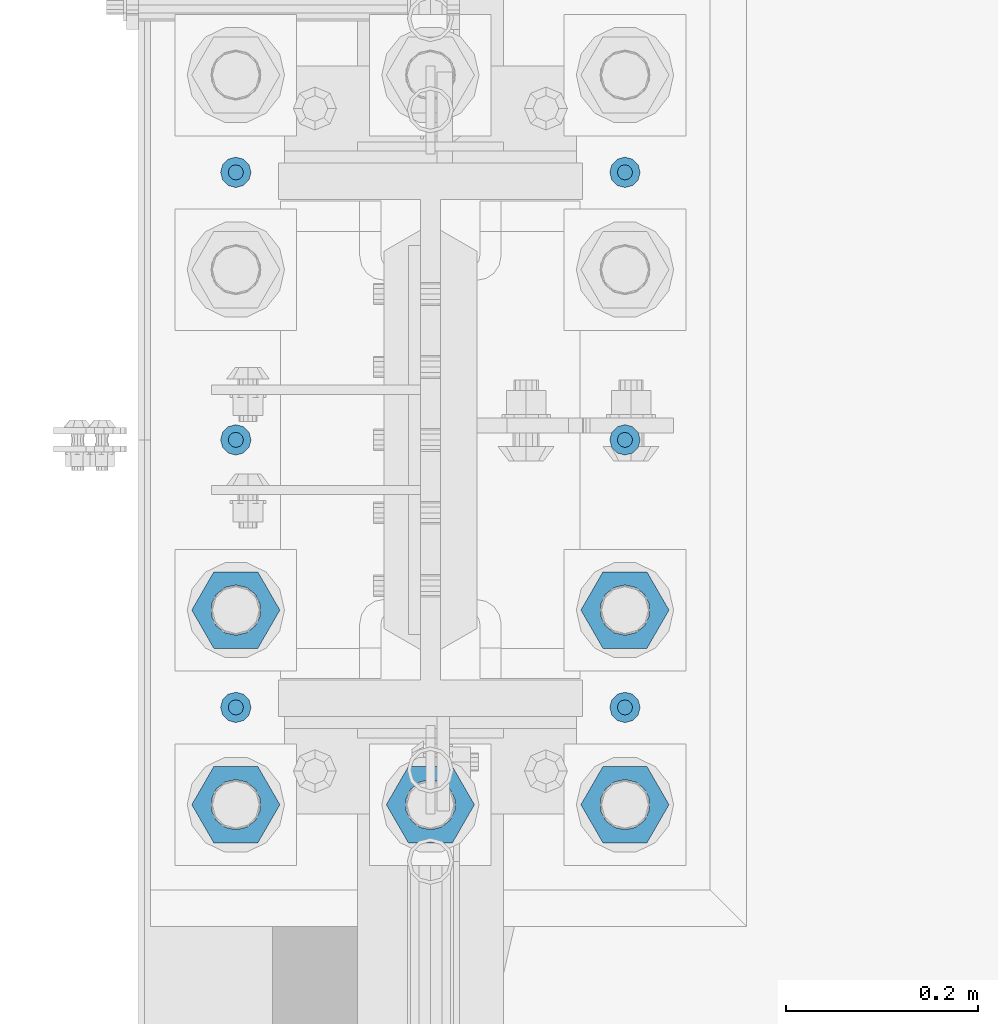
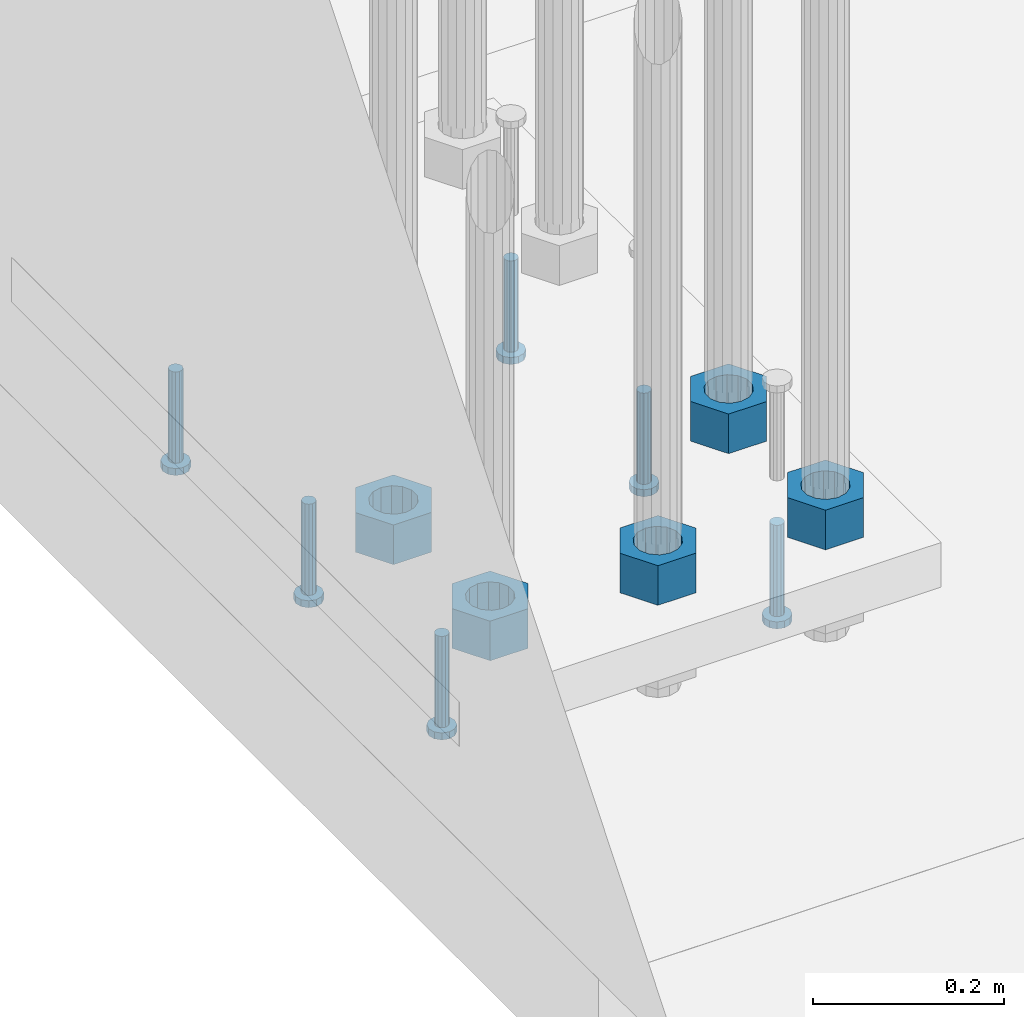
# One storey, part 1290 of 1876: 11 beams, 1 element without a shape of its own.
"""IFC2X3 building model written with IfcOpenShell, lengths in millimetres."""

from ifc_helpers import new_model, si_unit, frame, origin_with_axes, place, context, subcontext, project, spatial, faceted_brep, material, type_object, element, aggregate, save


model = new_model("IFC2X3")

# Units and contexts
model_context = context("Model", 3, precision=1e-05, world=origin_with_axes())
body_context = subcontext(model_context, "Body", "Model", "MODEL_VIEW")
ifc_project = project(units=[si_unit("LENGTHUNIT", "METRE", prefix="MILLI"), si_unit("AREAUNIT", "SQUARE_METRE"), si_unit("VOLUMEUNIT", "CUBIC_METRE"), si_unit("MASSUNIT", "GRAM", prefix="KILO"), si_unit("TIMEUNIT", "SECOND"), si_unit("PLANEANGLEUNIT", "RADIAN"), si_unit("SOLIDANGLEUNIT", "STERADIAN"), si_unit("THERMODYNAMICTEMPERATUREUNIT", "DEGREE_CELSIUS"), si_unit("LUMINOUSINTENSITYUNIT", "LUMEN")], contexts=[model_context])

# Site, building, storey
site_placement = place(None, origin_with_axes())
site = spatial("IfcSite", under=ifc_project, at=site_placement, CompositionType="ELEMENT")
building_placement = place(site_placement, origin_with_axes())
building = spatial("IfcBuilding", under=site, at=building_placement, Name="Undefined", CompositionType="ELEMENT")
storey_placement = place(building_placement, origin_with_axes())
storey = spatial("IfcBuildingStorey", under=building, at=storey_placement, Name="Undefined", CompositionType="ELEMENT", Elevation=0.0)

# Assembly, beams
assembly_placement = place(storey_placement, origin_with_axes())
assembly = element("IfcElementAssembly", 1, at=assembly_placement, inside=storey, Name="TEMPLATE", AssemblyPlace="NOTDEFINED", PredefinedType="RIGID_FRAME")
ifc_material_1 = material(Name="STEEL/A563")
beam_type_1 = type_object("IfcBeamType", Name="2_HEAVY_HEX_NUT", PredefinedType="NOTDEFINED")
beam_1_placement = place(assembly_placement, frame((-203.2, 7238.99999847412, -685.799998474121), z_axis=(0.0, -1.0, 0.0), x_axis=(0.0, 0.0, -1.0)))
beam_1 = element("IfcBeam", 2, at=beam_1_placement, type_object=beam_type_1, material=ifc_material_1, Name="NUT", ObjectType="2_HEAVY_HEX_NUT", context=body_context, shape_type="Brep", body=[
    faceted_brep([(0.0, -46.0369987487793, 9.09494701772928e-13), (0.0, -23.0184993743896, -39.869213104248), (50.8, -23.0184993743896, -39.869213104248), (50.8, -46.0369987487793, 9.09494701772928e-13), (0.0, 23.0184993743896, -39.869213104248), (50.8, 23.0184993743896, -39.869213104248), (0.0, 46.0369987487793, -9.09494701772928e-13), (50.8, 46.0369987487793, -9.09494701772928e-13), (0.0, 23.0184993743896, 39.869213104248), (50.8, 23.0184993743896, 39.869213104248), (0.0, -23.0184993743896, 39.869213104248), (50.8, -23.0184993743896, 39.869213104248), (0.0, 0.0, 26.1940002441406), (0.0, 11.3650617044514, 23.5999013092769), (50.8, 11.3650617044513, 23.5999013092771), (50.8, 0.0, 26.1940002441406), (0.0, 20.4791109456437, 16.3316083006703), (50.8, 20.4791109456439, 16.3316083006703), (0.0, 25.5370200498346, 5.82867859874477), (50.8, 25.5370200498343, 5.82867859874455), (0.0, 25.5370200498346, -5.82867859874477), (50.8, 25.5370200498343, -5.82867859874455), (0.0, 20.4791109456437, -16.3316083006703), (50.8, 20.4791109456439, -16.3316083006703), (0.0, 11.3650617044514, -23.5999013092769), (50.8, 11.3650617044514, -23.5999013092771), (0.0, 0.0, -26.1940002441406), (50.8, 0.0, -26.1940002441406), (0.0, -11.3650617044514, -23.5999013092769), (50.8, -11.3650617044513, -23.5999013092771), (0.0, -20.4791109456437, -16.3316083006703), (50.8, -20.4791109456439, -16.3316083006703), (0.0, -25.5370200498346, -5.82867859874477), (50.8, -25.5370200498343, -5.82867859874455), (0.0, -25.5370200498346, 5.82867859874477), (50.8, -25.5370200498343, 5.82867859874455), (0.0, -20.4791109456437, 16.3316083006703), (50.8, -20.4791109456439, 16.3316083006703), (0.0, -11.3650617044514, 23.5999013092769), (50.8, -11.3650617044514, 23.5999013092771)], [[[0, 1, 2, 3]], [[1, 4, 5, 2]], [[4, 6, 7, 5]], [[6, 8, 9, 7]], [[8, 10, 11, 9]], [[10, 0, 3, 11]], [[12, 13, 14, 15]], [[13, 16, 17, 14]], [[16, 18, 19, 17]], [[18, 20, 21, 19]], [[20, 22, 23, 21]], [[22, 24, 25, 23]], [[24, 26, 27, 25]], [[26, 28, 29, 27]], [[28, 30, 31, 29]], [[30, 32, 33, 31]], [[32, 34, 35, 33]], [[34, 36, 37, 35]], [[36, 38, 39, 37]], [[38, 12, 15, 39]], [[5, 7, 9, 11, 3, 2], [17, 19, 21, 23, 25, 27, 29, 31, 33, 35, 37, 39, 15, 14]], [[10, 8, 6, 4, 1, 0], [38, 36, 34, 32, 30, 28, 26, 24, 22, 20, 18, 16, 13, 12]]]),
])
beam_2_placement = place(assembly_placement, frame((0.0, 7238.99999847412, -685.799998474121), z_axis=(0.0, -1.0, 0.0), x_axis=(0.0, 0.0, -1.0)))
beam_2 = element("IfcBeam", 3, at=beam_2_placement, type_object=beam_type_1, material=ifc_material_1, Name="NUT", ObjectType="2_HEAVY_HEX_NUT", context=body_context, shape_type="Brep", body=[
    faceted_brep([(0.0, -46.0369987487793, 9.09494701772928e-13), (0.0, -23.0184993743896, -39.869213104248), (50.8, -23.0184993743896, -39.869213104248), (50.8, -46.0369987487793, 9.09494701772928e-13), (0.0, 23.0184993743896, -39.869213104248), (50.8, 23.0184993743896, -39.869213104248), (0.0, 46.0369987487793, -9.09494701772928e-13), (50.8, 46.0369987487793, -9.09494701772928e-13), (0.0, 23.0184993743896, 39.869213104248), (50.8, 23.0184993743896, 39.869213104248), (0.0, -23.0184993743896, 39.869213104248), (50.8, -23.0184993743896, 39.869213104248), (0.0, 0.0, 26.1940002441406), (0.0, 11.3650617044514, 23.5999013092769), (50.8, 11.3650617044513, 23.5999013092771), (50.8, 0.0, 26.1940002441406), (0.0, 20.4791109456437, 16.3316083006703), (50.8, 20.4791109456439, 16.3316083006703), (0.0, 25.5370200498346, 5.82867859874477), (50.8, 25.5370200498343, 5.82867859874455), (0.0, 25.5370200498346, -5.82867859874477), (50.8, 25.5370200498343, -5.82867859874455), (0.0, 20.4791109456437, -16.3316083006703), (50.8, 20.4791109456439, -16.3316083006703), (0.0, 11.3650617044514, -23.5999013092769), (50.8, 11.3650617044514, -23.5999013092771), (0.0, 0.0, -26.1940002441406), (50.8, 0.0, -26.1940002441406), (0.0, -11.3650617044514, -23.5999013092769), (50.8, -11.3650617044513, -23.5999013092771), (0.0, -20.4791109456437, -16.3316083006703), (50.8, -20.4791109456439, -16.3316083006703), (0.0, -25.5370200498346, -5.82867859874477), (50.8, -25.5370200498343, -5.82867859874455), (0.0, -25.5370200498346, 5.82867859874477), (50.8, -25.5370200498343, 5.82867859874455), (0.0, -20.4791109456437, 16.3316083006703), (50.8, -20.4791109456439, 16.3316083006703), (0.0, -11.3650617044514, 23.5999013092769), (50.8, -11.3650617044514, 23.5999013092771)], [[[0, 1, 2, 3]], [[1, 4, 5, 2]], [[4, 6, 7, 5]], [[6, 8, 9, 7]], [[8, 10, 11, 9]], [[10, 0, 3, 11]], [[12, 13, 14, 15]], [[13, 16, 17, 14]], [[16, 18, 19, 17]], [[18, 20, 21, 19]], [[20, 22, 23, 21]], [[22, 24, 25, 23]], [[24, 26, 27, 25]], [[26, 28, 29, 27]], [[28, 30, 31, 29]], [[30, 32, 33, 31]], [[32, 34, 35, 33]], [[34, 36, 37, 35]], [[36, 38, 39, 37]], [[38, 12, 15, 39]], [[5, 7, 9, 11, 3, 2], [17, 19, 21, 23, 25, 27, 29, 31, 33, 35, 37, 39, 15, 14]], [[10, 8, 6, 4, 1, 0], [38, 36, 34, 32, 30, 28, 26, 24, 22, 20, 18, 16, 13, 12]]]),
])
beam_3_placement = place(assembly_placement, frame((203.2, 7238.99999847412, -685.799998474121), z_axis=(0.0, 1.0, 0.0), x_axis=(0.0, 0.0, -1.0)))
beam_3 = element("IfcBeam", 4, at=beam_3_placement, type_object=beam_type_1, material=ifc_material_1, Name="NUT", ObjectType="2_HEAVY_HEX_NUT", context=body_context, shape_type="Brep", body=[
    faceted_brep([(0.0, -46.0369987487793, 9.09494701772928e-13), (0.0, -23.0184993743896, -39.869213104248), (50.8, -23.0184993743896, -39.869213104248), (50.8, -46.0369987487793, 9.09494701772928e-13), (0.0, 23.0184993743896, -39.869213104248), (50.8, 23.0184993743896, -39.869213104248), (0.0, 46.0369987487793, -9.09494701772928e-13), (50.8, 46.0369987487793, -9.09494701772928e-13), (0.0, 23.0184993743896, 39.869213104248), (50.8, 23.0184993743896, 39.869213104248), (0.0, -23.0184993743896, 39.869213104248), (50.8, -23.0184993743896, 39.869213104248), (0.0, 0.0, 26.1940002441406), (0.0, 11.3650617044514, 23.5999013092769), (50.8, 11.3650617044513, 23.5999013092771), (50.8, 0.0, 26.1940002441406), (0.0, 20.4791109456437, 16.3316083006703), (50.8, 20.4791109456439, 16.3316083006703), (0.0, 25.5370200498346, 5.82867859874477), (50.8, 25.5370200498343, 5.82867859874455), (0.0, 25.5370200498346, -5.82867859874477), (50.8, 25.5370200498343, -5.82867859874455), (0.0, 20.4791109456437, -16.3316083006703), (50.8, 20.4791109456439, -16.3316083006703), (0.0, 11.3650617044514, -23.5999013092769), (50.8, 11.3650617044514, -23.5999013092771), (0.0, 0.0, -26.1940002441406), (50.8, 0.0, -26.1940002441406), (0.0, -11.3650617044514, -23.5999013092769), (50.8, -11.3650617044513, -23.5999013092771), (0.0, -20.4791109456437, -16.3316083006703), (50.8, -20.4791109456439, -16.3316083006703), (0.0, -25.5370200498346, -5.82867859874477), (50.8, -25.5370200498343, -5.82867859874455), (0.0, -25.5370200498346, 5.82867859874477), (50.8, -25.5370200498343, 5.82867859874455), (0.0, -20.4791109456437, 16.3316083006703), (50.8, -20.4791109456439, 16.3316083006703), (0.0, -11.3650617044514, 23.5999013092769), (50.8, -11.3650617044514, 23.5999013092771)], [[[0, 1, 2, 3]], [[1, 4, 5, 2]], [[4, 6, 7, 5]], [[6, 8, 9, 7]], [[8, 10, 11, 9]], [[10, 0, 3, 11]], [[12, 13, 14, 15]], [[13, 16, 17, 14]], [[16, 18, 19, 17]], [[18, 20, 21, 19]], [[20, 22, 23, 21]], [[22, 24, 25, 23]], [[24, 26, 27, 25]], [[26, 28, 29, 27]], [[28, 30, 31, 29]], [[30, 32, 33, 31]], [[32, 34, 35, 33]], [[34, 36, 37, 35]], [[36, 38, 39, 37]], [[38, 12, 15, 39]], [[5, 7, 9, 11, 3, 2], [17, 19, 21, 23, 25, 27, 29, 31, 33, 35, 37, 39, 15, 14]], [[10, 8, 6, 4, 1, 0], [38, 36, 34, 32, 30, 28, 26, 24, 22, 20, 18, 16, 13, 12]]]),
])
beam_4_placement = place(assembly_placement, frame((-203.2, 7442.19999847412, -685.799998474121), z_axis=(0.0, -1.0, 0.0), x_axis=(0.0, 0.0, -1.0)))
beam_4 = element("IfcBeam", 5, at=beam_4_placement, type_object=beam_type_1, material=ifc_material_1, Name="NUT", ObjectType="2_HEAVY_HEX_NUT", context=body_context, shape_type="Brep", body=[
    faceted_brep([(0.0, -46.0369987487793, 9.09494701772928e-13), (0.0, -23.0184993743896, -39.869213104248), (50.8, -23.0184993743896, -39.869213104248), (50.8, -46.0369987487793, 9.09494701772928e-13), (0.0, 23.0184993743896, -39.869213104248), (50.8, 23.0184993743896, -39.869213104248), (0.0, 46.0369987487793, -9.09494701772928e-13), (50.8, 46.0369987487793, -9.09494701772928e-13), (0.0, 23.0184993743896, 39.869213104248), (50.8, 23.0184993743896, 39.869213104248), (0.0, -23.0184993743896, 39.869213104248), (50.8, -23.0184993743896, 39.869213104248), (0.0, 0.0, 26.1940002441406), (0.0, 11.3650617044514, 23.5999013092769), (50.8, 11.3650617044513, 23.5999013092771), (50.8, 0.0, 26.1940002441406), (0.0, 20.4791109456437, 16.3316083006703), (50.8, 20.4791109456439, 16.3316083006703), (0.0, 25.5370200498346, 5.82867859874477), (50.8, 25.5370200498343, 5.82867859874455), (0.0, 25.5370200498346, -5.82867859874477), (50.8, 25.5370200498343, -5.82867859874455), (0.0, 20.4791109456437, -16.3316083006703), (50.8, 20.4791109456439, -16.3316083006703), (0.0, 11.3650617044514, -23.5999013092769), (50.8, 11.3650617044514, -23.5999013092771), (0.0, 0.0, -26.1940002441406), (50.8, 0.0, -26.1940002441406), (0.0, -11.3650617044514, -23.5999013092769), (50.8, -11.3650617044513, -23.5999013092771), (0.0, -20.4791109456437, -16.3316083006703), (50.8, -20.4791109456439, -16.3316083006703), (0.0, -25.5370200498346, -5.82867859874477), (50.8, -25.5370200498343, -5.82867859874455), (0.0, -25.5370200498346, 5.82867859874477), (50.8, -25.5370200498343, 5.82867859874455), (0.0, -20.4791109456437, 16.3316083006703), (50.8, -20.4791109456439, 16.3316083006703), (0.0, -11.3650617044514, 23.5999013092769), (50.8, -11.3650617044514, 23.5999013092771)], [[[0, 1, 2, 3]], [[1, 4, 5, 2]], [[4, 6, 7, 5]], [[6, 8, 9, 7]], [[8, 10, 11, 9]], [[10, 0, 3, 11]], [[12, 13, 14, 15]], [[13, 16, 17, 14]], [[16, 18, 19, 17]], [[18, 20, 21, 19]], [[20, 22, 23, 21]], [[22, 24, 25, 23]], [[24, 26, 27, 25]], [[26, 28, 29, 27]], [[28, 30, 31, 29]], [[30, 32, 33, 31]], [[32, 34, 35, 33]], [[34, 36, 37, 35]], [[36, 38, 39, 37]], [[38, 12, 15, 39]], [[5, 7, 9, 11, 3, 2], [17, 19, 21, 23, 25, 27, 29, 31, 33, 35, 37, 39, 15, 14]], [[10, 8, 6, 4, 1, 0], [38, 36, 34, 32, 30, 28, 26, 24, 22, 20, 18, 16, 13, 12]]]),
])
beam_5_placement = place(assembly_placement, frame((203.2, 7442.19999847412, -685.799998474121), z_axis=(0.0, 1.0, 0.0), x_axis=(0.0, 0.0, -1.0)))
beam_5 = element("IfcBeam", 6, at=beam_5_placement, type_object=beam_type_1, material=ifc_material_1, Name="NUT", ObjectType="2_HEAVY_HEX_NUT", context=body_context, shape_type="Brep", body=[
    faceted_brep([(0.0, -46.0369987487793, 9.09494701772928e-13), (0.0, -23.0184993743896, -39.869213104248), (50.8, -23.0184993743896, -39.869213104248), (50.8, -46.0369987487793, 9.09494701772928e-13), (0.0, 23.0184993743896, -39.869213104248), (50.8, 23.0184993743896, -39.869213104248), (0.0, 46.0369987487793, -9.09494701772928e-13), (50.8, 46.0369987487793, -9.09494701772928e-13), (0.0, 23.0184993743896, 39.869213104248), (50.8, 23.0184993743896, 39.869213104248), (0.0, -23.0184993743896, 39.869213104248), (50.8, -23.0184993743896, 39.869213104248), (0.0, 0.0, 26.1940002441406), (0.0, 11.3650617044514, 23.5999013092769), (50.8, 11.3650617044513, 23.5999013092771), (50.8, 0.0, 26.1940002441406), (0.0, 20.4791109456437, 16.3316083006703), (50.8, 20.4791109456439, 16.3316083006703), (0.0, 25.5370200498346, 5.82867859874477), (50.8, 25.5370200498343, 5.82867859874455), (0.0, 25.5370200498346, -5.82867859874477), (50.8, 25.5370200498343, -5.82867859874455), (0.0, 20.4791109456437, -16.3316083006703), (50.8, 20.4791109456439, -16.3316083006703), (0.0, 11.3650617044514, -23.5999013092769), (50.8, 11.3650617044514, -23.5999013092771), (0.0, 0.0, -26.1940002441406), (50.8, 0.0, -26.1940002441406), (0.0, -11.3650617044514, -23.5999013092769), (50.8, -11.3650617044513, -23.5999013092771), (0.0, -20.4791109456437, -16.3316083006703), (50.8, -20.4791109456439, -16.3316083006703), (0.0, -25.5370200498346, -5.82867859874477), (50.8, -25.5370200498343, -5.82867859874455), (0.0, -25.5370200498346, 5.82867859874477), (50.8, -25.5370200498343, 5.82867859874455), (0.0, -20.4791109456437, 16.3316083006703), (50.8, -20.4791109456439, 16.3316083006703), (0.0, -11.3650617044514, 23.5999013092769), (50.8, -11.3650617044514, 23.5999013092771)], [[[0, 1, 2, 3]], [[1, 4, 5, 2]], [[4, 6, 7, 5]], [[6, 8, 9, 7]], [[8, 10, 11, 9]], [[10, 0, 3, 11]], [[12, 13, 14, 15]], [[13, 16, 17, 14]], [[16, 18, 19, 17]], [[18, 20, 21, 19]], [[20, 22, 23, 21]], [[22, 24, 25, 23]], [[24, 26, 27, 25]], [[26, 28, 29, 27]], [[28, 30, 31, 29]], [[30, 32, 33, 31]], [[32, 34, 35, 33]], [[34, 36, 37, 35]], [[36, 38, 39, 37]], [[38, 12, 15, 39]], [[5, 7, 9, 11, 3, 2], [17, 19, 21, 23, 25, 27, 29, 31, 33, 35, 37, 39, 15, 14]], [[10, 8, 6, 4, 1, 0], [38, 36, 34, 32, 30, 28, 26, 24, 22, 20, 18, 16, 13, 12]]]),
])
ifc_material_2 = material(Name="STEEL/A108")
beam_type_2 = type_object("IfcBeamType", Name="5/8-DIA_HEADED ANCHOR STUD", PredefinedType="NOTDEFINED")
beam_6_placement = place(assembly_placement, frame((203.2, 7899.4, -793.75), z_axis=(1.0, 0.0, 0.0), x_axis=(0.0, 0.0, -1.0)))
beam_6 = element("IfcBeam", 7, at=beam_6_placement, type_object=beam_type_2, material=ifc_material_2, Name="HEADED ANCHOR STUD", ObjectType="5/8-DIA_HEADED ANCHOR STUD", context=body_context, shape_type="Brep", body=[
    faceted_brep([(0.0, -7.94000005722046, 0.0), (0.0, -6.86999988555908, -3.97000002861023), (116.84, -6.86999988555908, -3.97000002861023), (116.84, -7.94000005722046, 0.0), (0.0, -3.97000002861023, -6.86999988555908), (116.84, -3.97000002861023, -6.86999988555908), (0.0, 0.0, -7.94000005722046), (116.84, 0.0, -7.94000005722046), (0.0, 3.97000002861023, -6.86999988555908), (116.84, 3.97000002861023, -6.86999988555908), (0.0, 6.86999988555908, -3.97000002861023), (116.84, 6.86999988555908, -3.97000002861023), (0.0, 7.94000005722046, 0.0), (116.84, 7.94000005722046, 0.0), (0.0, 6.86999988555908, 3.97000002861023), (116.84, 6.86999988555908, 3.97000002861023), (0.0, 3.97000002861023, 6.86999988555908), (116.84, 3.97000002861023, 6.86999988555908), (0.0, 0.0, 7.94000005722046), (116.84, 0.0, 7.94000005722046), (0.0, -3.97000002861023, 6.86999988555908), (116.84, -3.97000002861023, 6.86999988555908), (0.0, -6.86999988555908, 3.97000002861023), (116.84, -6.86999988555908, 3.97000002861023), (118.11, -13.75, -7.94000005722046), (118.11, -15.8800001144409, 0.0), (118.11, -7.94000005722046, -13.75), (118.11, 0.0, -15.8800001144409), (118.11, 7.94000005722046, -13.75), (118.11, 13.75, -7.94000005722046), (118.11, 15.8800001144409, 0.0), (118.11, 13.75, 7.94000005722046), (118.11, 7.94000005722046, 13.75), (118.11, 0.0, 15.8800001144409), (118.11, -7.94000005722046, 13.75), (118.11, -13.75, 7.94000005722046), (127.0, -13.75, -7.94000005722046), (127.0, -15.8800001144409, 0.0), (127.0, -7.94000005722046, -13.75), (127.0, 0.0, -15.8800001144409), (127.0, 7.94000005722046, -13.75), (127.0, 13.75, -7.94000005722046), (127.0, 15.8800001144409, 0.0), (127.0, 13.75, 7.94000005722046), (127.0, 7.94000005722046, 13.75), (127.0, 0.0, 15.8800001144409), (127.0, -7.94000005722046, 13.75), (127.0, -13.75, 7.94000005722046)], [[[0, 1, 2, 3]], [[1, 4, 5, 2]], [[4, 6, 7, 5]], [[6, 8, 9, 7]], [[8, 10, 11, 9]], [[10, 12, 13, 11]], [[12, 14, 15, 13]], [[14, 16, 17, 15]], [[16, 18, 19, 17]], [[18, 20, 21, 19]], [[20, 22, 23, 21]], [[22, 0, 3, 23]], [[22, 20, 18, 16, 14, 12, 10, 8, 6, 4, 1, 0]], [[3, 2, 24, 25]], [[2, 5, 26, 24]], [[5, 7, 27, 26]], [[7, 9, 28, 27]], [[9, 11, 29, 28]], [[11, 13, 30, 29]], [[13, 15, 31, 30]], [[15, 17, 32, 31]], [[17, 19, 33, 32]], [[19, 21, 34, 33]], [[21, 23, 35, 34]], [[23, 3, 25, 35]], [[25, 24, 36, 37]], [[24, 26, 38, 36]], [[26, 27, 39, 38]], [[27, 28, 40, 39]], [[28, 29, 41, 40]], [[29, 30, 42, 41]], [[30, 31, 43, 42]], [[31, 32, 44, 43]], [[32, 33, 45, 44]], [[33, 34, 46, 45]], [[34, 35, 47, 46]], [[35, 25, 37, 47]], [[38, 39, 40, 41, 42, 43, 44, 45, 46, 47, 37, 36]]]),
])
beam_7_placement = place(assembly_placement, frame((203.2, 7340.6, -793.75), z_axis=(1.0, 0.0, 0.0), x_axis=(0.0, 0.0, -1.0)))
beam_7 = element("IfcBeam", 8, at=beam_7_placement, type_object=beam_type_2, material=ifc_material_2, Name="HEADED ANCHOR STUD", ObjectType="5/8-DIA_HEADED ANCHOR STUD", context=body_context, shape_type="Brep", body=[
    faceted_brep([(0.0, -7.94000005722046, 0.0), (0.0, -6.86999988555908, -3.97000002861023), (116.84, -6.86999988555908, -3.97000002861023), (116.84, -7.94000005722046, 0.0), (0.0, -3.97000002861023, -6.86999988555908), (116.84, -3.97000002861023, -6.86999988555908), (0.0, 0.0, -7.94000005722046), (116.84, 0.0, -7.94000005722046), (0.0, 3.97000002861023, -6.86999988555908), (116.84, 3.97000002861023, -6.86999988555908), (0.0, 6.86999988555908, -3.97000002861023), (116.84, 6.86999988555908, -3.97000002861023), (0.0, 7.94000005722046, 0.0), (116.84, 7.94000005722046, 0.0), (0.0, 6.86999988555908, 3.97000002861023), (116.84, 6.86999988555908, 3.97000002861023), (0.0, 3.97000002861023, 6.86999988555908), (116.84, 3.97000002861023, 6.86999988555908), (0.0, 0.0, 7.94000005722046), (116.84, 0.0, 7.94000005722046), (0.0, -3.97000002861023, 6.86999988555908), (116.84, -3.97000002861023, 6.86999988555908), (0.0, -6.86999988555908, 3.97000002861023), (116.84, -6.86999988555908, 3.97000002861023), (118.11, -13.75, -7.94000005722046), (118.11, -15.8800001144409, 0.0), (118.11, -7.94000005722046, -13.75), (118.11, 0.0, -15.8800001144409), (118.11, 7.94000005722046, -13.75), (118.11, 13.75, -7.94000005722046), (118.11, 15.8800001144409, 0.0), (118.11, 13.75, 7.94000005722046), (118.11, 7.94000005722046, 13.75), (118.11, 0.0, 15.8800001144409), (118.11, -7.94000005722046, 13.75), (118.11, -13.75, 7.94000005722046), (127.0, -13.75, -7.94000005722046), (127.0, -15.8800001144409, 0.0), (127.0, -7.94000005722046, -13.75), (127.0, 0.0, -15.8800001144409), (127.0, 7.94000005722046, -13.75), (127.0, 13.75, -7.94000005722046), (127.0, 15.8800001144409, 0.0), (127.0, 13.75, 7.94000005722046), (127.0, 7.94000005722046, 13.75), (127.0, 0.0, 15.8800001144409), (127.0, -7.94000005722046, 13.75), (127.0, -13.75, 7.94000005722046)], [[[0, 1, 2, 3]], [[1, 4, 5, 2]], [[4, 6, 7, 5]], [[6, 8, 9, 7]], [[8, 10, 11, 9]], [[10, 12, 13, 11]], [[12, 14, 15, 13]], [[14, 16, 17, 15]], [[16, 18, 19, 17]], [[18, 20, 21, 19]], [[20, 22, 23, 21]], [[22, 0, 3, 23]], [[22, 20, 18, 16, 14, 12, 10, 8, 6, 4, 1, 0]], [[3, 2, 24, 25]], [[2, 5, 26, 24]], [[5, 7, 27, 26]], [[7, 9, 28, 27]], [[9, 11, 29, 28]], [[11, 13, 30, 29]], [[13, 15, 31, 30]], [[15, 17, 32, 31]], [[17, 19, 33, 32]], [[19, 21, 34, 33]], [[21, 23, 35, 34]], [[23, 3, 25, 35]], [[25, 24, 36, 37]], [[24, 26, 38, 36]], [[26, 27, 39, 38]], [[27, 28, 40, 39]], [[28, 29, 41, 40]], [[29, 30, 42, 41]], [[30, 31, 43, 42]], [[31, 32, 44, 43]], [[32, 33, 45, 44]], [[33, 34, 46, 45]], [[34, 35, 47, 46]], [[35, 25, 37, 47]], [[38, 39, 40, 41, 42, 43, 44, 45, 46, 47, 37, 36]]]),
])
beam_8_placement = place(assembly_placement, frame((203.2, 7620.0, -793.75), z_axis=(1.0, 0.0, 0.0), x_axis=(0.0, 0.0, -1.0)))
beam_8 = element("IfcBeam", 9, at=beam_8_placement, type_object=beam_type_2, material=ifc_material_2, Name="HEADED ANCHOR STUD", ObjectType="5/8-DIA_HEADED ANCHOR STUD", context=body_context, shape_type="Brep", body=[
    faceted_brep([(0.0, -7.94000005722046, 0.0), (0.0, -6.86999988555908, -3.97000002861023), (116.84, -6.86999988555908, -3.97000002861023), (116.84, -7.94000005722046, 0.0), (0.0, -3.97000002861023, -6.86999988555908), (116.84, -3.97000002861023, -6.86999988555908), (0.0, 0.0, -7.94000005722046), (116.84, 0.0, -7.94000005722046), (0.0, 3.97000002861023, -6.86999988555908), (116.84, 3.97000002861023, -6.86999988555908), (0.0, 6.86999988555908, -3.97000002861023), (116.84, 6.86999988555908, -3.97000002861023), (0.0, 7.94000005722046, 0.0), (116.84, 7.94000005722046, 0.0), (0.0, 6.86999988555908, 3.97000002861023), (116.84, 6.86999988555908, 3.97000002861023), (0.0, 3.97000002861023, 6.86999988555908), (116.84, 3.97000002861023, 6.86999988555908), (0.0, 0.0, 7.94000005722046), (116.84, 0.0, 7.94000005722046), (0.0, -3.97000002861023, 6.86999988555908), (116.84, -3.97000002861023, 6.86999988555908), (0.0, -6.86999988555908, 3.97000002861023), (116.84, -6.86999988555908, 3.97000002861023), (118.11, -13.75, -7.94000005722046), (118.11, -15.8800001144409, 0.0), (118.11, -7.94000005722046, -13.75), (118.11, 0.0, -15.8800001144409), (118.11, 7.94000005722046, -13.75), (118.11, 13.75, -7.94000005722046), (118.11, 15.8800001144409, 0.0), (118.11, 13.75, 7.94000005722046), (118.11, 7.94000005722046, 13.75), (118.11, 0.0, 15.8800001144409), (118.11, -7.94000005722046, 13.75), (118.11, -13.75, 7.94000005722046), (127.0, -13.75, -7.94000005722046), (127.0, -15.8800001144409, 0.0), (127.0, -7.94000005722046, -13.75), (127.0, 0.0, -15.8800001144409), (127.0, 7.94000005722046, -13.75), (127.0, 13.75, -7.94000005722046), (127.0, 15.8800001144409, 0.0), (127.0, 13.75, 7.94000005722046), (127.0, 7.94000005722046, 13.75), (127.0, 0.0, 15.8800001144409), (127.0, -7.94000005722046, 13.75), (127.0, -13.75, 7.94000005722046)], [[[0, 1, 2, 3]], [[1, 4, 5, 2]], [[4, 6, 7, 5]], [[6, 8, 9, 7]], [[8, 10, 11, 9]], [[10, 12, 13, 11]], [[12, 14, 15, 13]], [[14, 16, 17, 15]], [[16, 18, 19, 17]], [[18, 20, 21, 19]], [[20, 22, 23, 21]], [[22, 0, 3, 23]], [[22, 20, 18, 16, 14, 12, 10, 8, 6, 4, 1, 0]], [[3, 2, 24, 25]], [[2, 5, 26, 24]], [[5, 7, 27, 26]], [[7, 9, 28, 27]], [[9, 11, 29, 28]], [[11, 13, 30, 29]], [[13, 15, 31, 30]], [[15, 17, 32, 31]], [[17, 19, 33, 32]], [[19, 21, 34, 33]], [[21, 23, 35, 34]], [[23, 3, 25, 35]], [[25, 24, 36, 37]], [[24, 26, 38, 36]], [[26, 27, 39, 38]], [[27, 28, 40, 39]], [[28, 29, 41, 40]], [[29, 30, 42, 41]], [[30, 31, 43, 42]], [[31, 32, 44, 43]], [[32, 33, 45, 44]], [[33, 34, 46, 45]], [[34, 35, 47, 46]], [[35, 25, 37, 47]], [[38, 39, 40, 41, 42, 43, 44, 45, 46, 47, 37, 36]]]),
])
beam_9_placement = place(assembly_placement, frame((-203.2, 7899.4, -793.75), z_axis=(1.0, 0.0, 0.0), x_axis=(0.0, 0.0, -1.0)))
beam_9 = element("IfcBeam", 10, at=beam_9_placement, type_object=beam_type_2, material=ifc_material_2, Name="HEADED ANCHOR STUD", ObjectType="5/8-DIA_HEADED ANCHOR STUD", context=body_context, shape_type="Brep", body=[
    faceted_brep([(0.0, -7.94000005722046, 0.0), (0.0, -6.86999988555908, -3.97000002861023), (116.84, -6.86999988555908, -3.97000002861023), (116.84, -7.94000005722046, 0.0), (0.0, -3.97000002861023, -6.86999988555908), (116.84, -3.97000002861023, -6.86999988555908), (0.0, 0.0, -7.94000005722046), (116.84, 0.0, -7.94000005722046), (0.0, 3.97000002861023, -6.86999988555908), (116.84, 3.97000002861023, -6.86999988555908), (0.0, 6.86999988555908, -3.97000002861023), (116.84, 6.86999988555908, -3.97000002861023), (0.0, 7.94000005722046, 0.0), (116.84, 7.94000005722046, 0.0), (0.0, 6.86999988555908, 3.97000002861023), (116.84, 6.86999988555908, 3.97000002861023), (0.0, 3.97000002861023, 6.86999988555908), (116.84, 3.97000002861023, 6.86999988555908), (0.0, 0.0, 7.94000005722046), (116.84, 0.0, 7.94000005722046), (0.0, -3.97000002861023, 6.86999988555908), (116.84, -3.97000002861023, 6.86999988555908), (0.0, -6.86999988555908, 3.97000002861023), (116.84, -6.86999988555908, 3.97000002861023), (118.11, -13.75, -7.94000005722046), (118.11, -15.8800001144409, 0.0), (118.11, -7.94000005722046, -13.75), (118.11, 0.0, -15.8800001144409), (118.11, 7.94000005722046, -13.75), (118.11, 13.75, -7.94000005722046), (118.11, 15.8800001144409, 0.0), (118.11, 13.75, 7.94000005722046), (118.11, 7.94000005722046, 13.75), (118.11, 0.0, 15.8800001144409), (118.11, -7.94000005722046, 13.75), (118.11, -13.75, 7.94000005722046), (127.0, -13.75, -7.94000005722046), (127.0, -15.8800001144409, 0.0), (127.0, -7.94000005722046, -13.75), (127.0, 0.0, -15.8800001144409), (127.0, 7.94000005722046, -13.75), (127.0, 13.75, -7.94000005722046), (127.0, 15.8800001144409, 0.0), (127.0, 13.75, 7.94000005722046), (127.0, 7.94000005722046, 13.75), (127.0, 0.0, 15.8800001144409), (127.0, -7.94000005722046, 13.75), (127.0, -13.75, 7.94000005722046)], [[[0, 1, 2, 3]], [[1, 4, 5, 2]], [[4, 6, 7, 5]], [[6, 8, 9, 7]], [[8, 10, 11, 9]], [[10, 12, 13, 11]], [[12, 14, 15, 13]], [[14, 16, 17, 15]], [[16, 18, 19, 17]], [[18, 20, 21, 19]], [[20, 22, 23, 21]], [[22, 0, 3, 23]], [[22, 20, 18, 16, 14, 12, 10, 8, 6, 4, 1, 0]], [[3, 2, 24, 25]], [[2, 5, 26, 24]], [[5, 7, 27, 26]], [[7, 9, 28, 27]], [[9, 11, 29, 28]], [[11, 13, 30, 29]], [[13, 15, 31, 30]], [[15, 17, 32, 31]], [[17, 19, 33, 32]], [[19, 21, 34, 33]], [[21, 23, 35, 34]], [[23, 3, 25, 35]], [[25, 24, 36, 37]], [[24, 26, 38, 36]], [[26, 27, 39, 38]], [[27, 28, 40, 39]], [[28, 29, 41, 40]], [[29, 30, 42, 41]], [[30, 31, 43, 42]], [[31, 32, 44, 43]], [[32, 33, 45, 44]], [[33, 34, 46, 45]], [[34, 35, 47, 46]], [[35, 25, 37, 47]], [[38, 39, 40, 41, 42, 43, 44, 45, 46, 47, 37, 36]]]),
])
beam_10_placement = place(assembly_placement, frame((-203.2, 7340.6, -793.75), z_axis=(1.0, 0.0, 0.0), x_axis=(0.0, 0.0, -1.0)))
beam_10 = element("IfcBeam", 11, at=beam_10_placement, type_object=beam_type_2, material=ifc_material_2, Name="HEADED ANCHOR STUD", ObjectType="5/8-DIA_HEADED ANCHOR STUD", context=body_context, shape_type="Brep", body=[
    faceted_brep([(0.0, -7.94000005722046, 0.0), (0.0, -6.86999988555908, -3.97000002861023), (116.84, -6.86999988555908, -3.97000002861023), (116.84, -7.94000005722046, 0.0), (0.0, -3.97000002861023, -6.86999988555908), (116.84, -3.97000002861023, -6.86999988555908), (0.0, 0.0, -7.94000005722046), (116.84, 0.0, -7.94000005722046), (0.0, 3.97000002861023, -6.86999988555908), (116.84, 3.97000002861023, -6.86999988555908), (0.0, 6.86999988555908, -3.97000002861023), (116.84, 6.86999988555908, -3.97000002861023), (0.0, 7.94000005722046, 0.0), (116.84, 7.94000005722046, 0.0), (0.0, 6.86999988555908, 3.97000002861023), (116.84, 6.86999988555908, 3.97000002861023), (0.0, 3.97000002861023, 6.86999988555908), (116.84, 3.97000002861023, 6.86999988555908), (0.0, 0.0, 7.94000005722046), (116.84, 0.0, 7.94000005722046), (0.0, -3.97000002861023, 6.86999988555908), (116.84, -3.97000002861023, 6.86999988555908), (0.0, -6.86999988555908, 3.97000002861023), (116.84, -6.86999988555908, 3.97000002861023), (118.11, -13.75, -7.94000005722046), (118.11, -15.8800001144409, 0.0), (118.11, -7.94000005722046, -13.75), (118.11, 0.0, -15.8800001144409), (118.11, 7.94000005722046, -13.75), (118.11, 13.75, -7.94000005722046), (118.11, 15.8800001144409, 0.0), (118.11, 13.75, 7.94000005722046), (118.11, 7.94000005722046, 13.75), (118.11, 0.0, 15.8800001144409), (118.11, -7.94000005722046, 13.75), (118.11, -13.75, 7.94000005722046), (127.0, -13.75, -7.94000005722046), (127.0, -15.8800001144409, 0.0), (127.0, -7.94000005722046, -13.75), (127.0, 0.0, -15.8800001144409), (127.0, 7.94000005722046, -13.75), (127.0, 13.75, -7.94000005722046), (127.0, 15.8800001144409, 0.0), (127.0, 13.75, 7.94000005722046), (127.0, 7.94000005722046, 13.75), (127.0, 0.0, 15.8800001144409), (127.0, -7.94000005722046, 13.75), (127.0, -13.75, 7.94000005722046)], [[[0, 1, 2, 3]], [[1, 4, 5, 2]], [[4, 6, 7, 5]], [[6, 8, 9, 7]], [[8, 10, 11, 9]], [[10, 12, 13, 11]], [[12, 14, 15, 13]], [[14, 16, 17, 15]], [[16, 18, 19, 17]], [[18, 20, 21, 19]], [[20, 22, 23, 21]], [[22, 0, 3, 23]], [[22, 20, 18, 16, 14, 12, 10, 8, 6, 4, 1, 0]], [[3, 2, 24, 25]], [[2, 5, 26, 24]], [[5, 7, 27, 26]], [[7, 9, 28, 27]], [[9, 11, 29, 28]], [[11, 13, 30, 29]], [[13, 15, 31, 30]], [[15, 17, 32, 31]], [[17, 19, 33, 32]], [[19, 21, 34, 33]], [[21, 23, 35, 34]], [[23, 3, 25, 35]], [[25, 24, 36, 37]], [[24, 26, 38, 36]], [[26, 27, 39, 38]], [[27, 28, 40, 39]], [[28, 29, 41, 40]], [[29, 30, 42, 41]], [[30, 31, 43, 42]], [[31, 32, 44, 43]], [[32, 33, 45, 44]], [[33, 34, 46, 45]], [[34, 35, 47, 46]], [[35, 25, 37, 47]], [[38, 39, 40, 41, 42, 43, 44, 45, 46, 47, 37, 36]]]),
])
beam_11_placement = place(assembly_placement, frame((-203.2, 7620.0, -793.75), z_axis=(1.0, 0.0, 0.0), x_axis=(0.0, 0.0, -1.0)))
beam_11 = element("IfcBeam", 12, at=beam_11_placement, type_object=beam_type_2, material=ifc_material_2, Name="HEADED ANCHOR STUD", ObjectType="5/8-DIA_HEADED ANCHOR STUD", context=body_context, shape_type="Brep", body=[
    faceted_brep([(0.0, -7.94000005722046, 0.0), (0.0, -6.86999988555908, -3.97000002861023), (116.84, -6.86999988555908, -3.97000002861023), (116.84, -7.94000005722046, 0.0), (0.0, -3.97000002861023, -6.86999988555908), (116.84, -3.97000002861023, -6.86999988555908), (0.0, 0.0, -7.94000005722046), (116.84, 0.0, -7.94000005722046), (0.0, 3.97000002861023, -6.86999988555908), (116.84, 3.97000002861023, -6.86999988555908), (0.0, 6.86999988555908, -3.97000002861023), (116.84, 6.86999988555908, -3.97000002861023), (0.0, 7.94000005722046, 0.0), (116.84, 7.94000005722046, 0.0), (0.0, 6.86999988555908, 3.97000002861023), (116.84, 6.86999988555908, 3.97000002861023), (0.0, 3.97000002861023, 6.86999988555908), (116.84, 3.97000002861023, 6.86999988555908), (0.0, 0.0, 7.94000005722046), (116.84, 0.0, 7.94000005722046), (0.0, -3.97000002861023, 6.86999988555908), (116.84, -3.97000002861023, 6.86999988555908), (0.0, -6.86999988555908, 3.97000002861023), (116.84, -6.86999988555908, 3.97000002861023), (118.11, -13.75, -7.94000005722046), (118.11, -15.8800001144409, 0.0), (118.11, -7.94000005722046, -13.75), (118.11, 0.0, -15.8800001144409), (118.11, 7.94000005722046, -13.75), (118.11, 13.75, -7.94000005722046), (118.11, 15.8800001144409, 0.0), (118.11, 13.75, 7.94000005722046), (118.11, 7.94000005722046, 13.75), (118.11, 0.0, 15.8800001144409), (118.11, -7.94000005722046, 13.75), (118.11, -13.75, 7.94000005722046), (127.0, -13.75, -7.94000005722046), (127.0, -15.8800001144409, 0.0), (127.0, -7.94000005722046, -13.75), (127.0, 0.0, -15.8800001144409), (127.0, 7.94000005722046, -13.75), (127.0, 13.75, -7.94000005722046), (127.0, 15.8800001144409, 0.0), (127.0, 13.75, 7.94000005722046), (127.0, 7.94000005722046, 13.75), (127.0, 0.0, 15.8800001144409), (127.0, -7.94000005722046, 13.75), (127.0, -13.75, 7.94000005722046)], [[[0, 1, 2, 3]], [[1, 4, 5, 2]], [[4, 6, 7, 5]], [[6, 8, 9, 7]], [[8, 10, 11, 9]], [[10, 12, 13, 11]], [[12, 14, 15, 13]], [[14, 16, 17, 15]], [[16, 18, 19, 17]], [[18, 20, 21, 19]], [[20, 22, 23, 21]], [[22, 0, 3, 23]], [[22, 20, 18, 16, 14, 12, 10, 8, 6, 4, 1, 0]], [[3, 2, 24, 25]], [[2, 5, 26, 24]], [[5, 7, 27, 26]], [[7, 9, 28, 27]], [[9, 11, 29, 28]], [[11, 13, 30, 29]], [[13, 15, 31, 30]], [[15, 17, 32, 31]], [[17, 19, 33, 32]], [[19, 21, 34, 33]], [[21, 23, 35, 34]], [[23, 3, 25, 35]], [[25, 24, 36, 37]], [[24, 26, 38, 36]], [[26, 27, 39, 38]], [[27, 28, 40, 39]], [[28, 29, 41, 40]], [[29, 30, 42, 41]], [[30, 31, 43, 42]], [[31, 32, 44, 43]], [[32, 33, 45, 44]], [[33, 34, 46, 45]], [[34, 35, 47, 46]], [[35, 25, 37, 47]], [[38, 39, 40, 41, 42, 43, 44, 45, 46, 47, 37, 36]]]),
])
aggregate(assembly, [beam_6, beam_7, beam_8, beam_9, beam_10, beam_11, beam_1, beam_2, beam_3, beam_4, beam_5])

save(model, "model.ifc")
